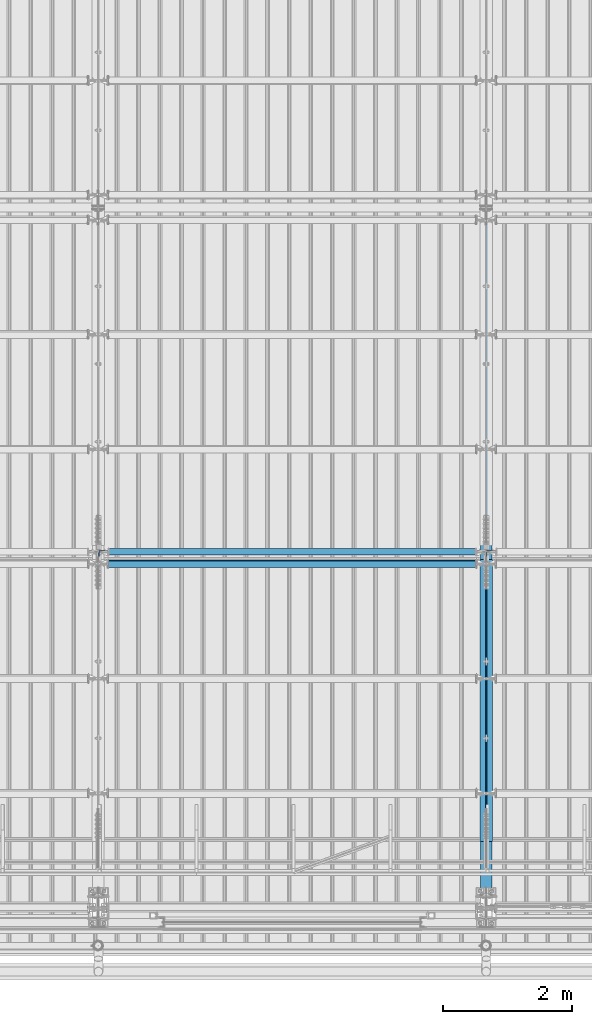
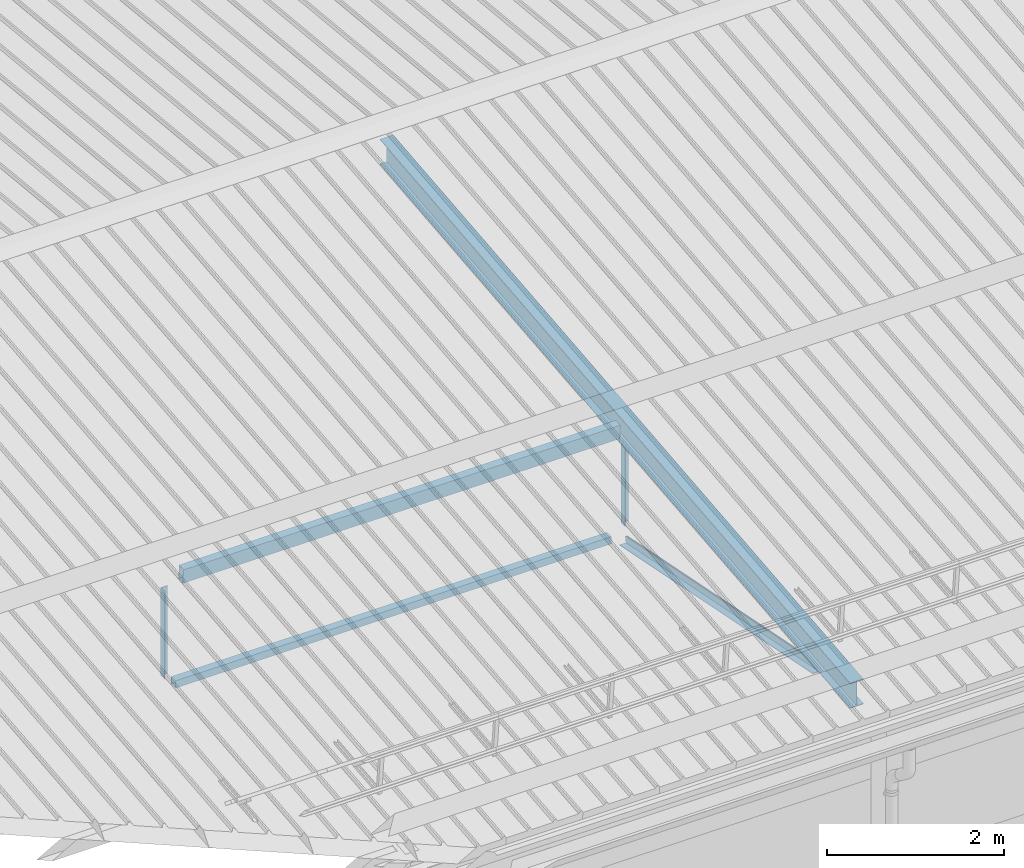
# One storey, part 252 of 709: 7 beams, 7 elements without a shape of their own.
"""IFC4 building model written with IfcOpenShell, lengths in millimetres."""

from ifc_helpers import new_model, si_unit, direction, frame, origin_with_axes, place, context, subcontext, project, spatial, polygons, material, element, aggregate, save


model = new_model("IFC4")

# Units and contexts
model_context = context("Model", 3, precision=0.2, world=origin_with_axes(), true_north=direction((0.0, 1.0)))
body_context = subcontext(model_context, "Body", "Model", "MODEL_VIEW")
ifc_project = project(units=[si_unit("LENGTHUNIT", "METRE", prefix="MILLI"), si_unit("AREAUNIT", "SQUARE_METRE"), si_unit("VOLUMEUNIT", "CUBIC_METRE"), si_unit("MASSUNIT", "GRAM", prefix="KILO"), si_unit("TIMEUNIT", "SECOND"), si_unit("PLANEANGLEUNIT", "RADIAN"), si_unit("SOLIDANGLEUNIT", "STERADIAN"), si_unit("THERMODYNAMICTEMPERATUREUNIT", "DEGREE_CELSIUS"), si_unit("LUMINOUSINTENSITYUNIT", "LUMEN")], contexts=[model_context])

# Site, building, storey
site_placement = place(None, origin_with_axes())
site = spatial("IfcSite", under=ifc_project, at=site_placement, CompositionType="ELEMENT")
building_placement = place(site_placement, origin_with_axes())
building = spatial("IfcBuilding", under=site, at=building_placement, Name="Undefined", CompositionType="ELEMENT")
storey_placement = place(building_placement, origin_with_axes())
storey = spatial("IfcBuildingStorey", under=building, at=storey_placement, Name="Undefined", CompositionType="ELEMENT", Elevation=0.0)

# Assembly, beam
assembly_1_placement = place(storey_placement, frame((16051.0, 5648.7, 7622.40002), z_axis=(0.0, -1.0, 0.0), x_axis=(0.0, 0.0, -1.0)))
assembly_1 = element("IfcElementAssembly", 1, at=assembly_1_placement, inside=storey)
ifc_material_1 = material(Name="C345-5", Category="STEEL")
beam_1_placement = place(assembly_1_placement, origin_with_axes())
beam_1 = element("IfcBeam", 2, at=beam_1_placement, material=ifc_material_1, ObjectType="436", context=body_context, shape_type="Tessellation", body=[
    polygons([(199.0491, -45.0, -45.0), (199.0491, 45.0, -45.0), (1412.4, 45.0, -45.0), (1412.4, -45.0, -45.0), (199.0491, 45.0, -39.0), (1412.4, 45.0, -39.0), (199.0491, -39.0, -39.0), (1412.4, -39.0, -39.0), (199.0491, -39.0, 45.0), (1412.4, -39.0, 45.0), (199.0491, -45.0, 45.0), (1412.4, -45.0, 45.0)], [[[1, 2, 3, 4]], [[2, 5, 6, 3]], [[5, 7, 8, 6]], [[7, 9, 10, 8]], [[9, 11, 12, 10]], [[11, 1, 4, 12]], [[6, 8, 10, 12, 4, 3]], [[11, 9, 7, 5, 2, 1]]], closed=True),
])
aggregate(assembly_1, [beam_1])

assembly_2_placement = place(storey_placement, frame((22000.0, 346.0, 7089.70002), z_axis=(1.0, 0.0, 0.0), x_axis=(0.0, 0.9950371902, 0.099503719)))
assembly_2 = element("IfcElementAssembly", 3, at=assembly_2_placement, inside=storey)
ifc_material_2 = material(Name="C355-5", Category="STEEL")
beam_2_placement = place(assembly_2_placement, origin_with_axes())
beam_2 = element("IfcBeam", 4, at=beam_2_placement, material=ifc_material_2, ObjectType="432", context=body_context, shape_type="Tessellation", body=[
    polygons([(3.80474, -173.0, -87.0), (4.70474, -164.0, -87.0), (10665.6128, -164.0, -87.0), (10664.7128, -173.0, -87.0), (4.70474, -164.0, -3.0), (10665.6128, -164.0, -3.0), (37.50474, 164.0, -3.0), (10698.4128, 164.0, -3.0), (37.50474, 164.0, -87.0), (10698.4128, 164.0, -87.0), (38.40474, 173.0, -87.0), (10699.3128, 173.0, -87.0), (38.40474, 173.0, 87.0), (10699.3128, 173.0, 87.0), (37.50474, 164.0, 87.0), (10698.4128, 164.0, 87.0), (37.50474, 164.0, 3.0), (10698.4128, 164.0, 3.0), (4.70474, -164.0, 3.0), (10665.6128, -164.0, 3.0), (4.70474, -164.0, 87.0), (10665.6128, -164.0, 87.0), (3.80474, -173.0, 87.0), (10664.7128, -173.0, 87.0)], [[[1, 2, 3, 4]], [[2, 5, 6, 3]], [[5, 7, 8, 6]], [[7, 9, 10, 8]], [[9, 11, 12, 10]], [[11, 13, 14, 12]], [[13, 15, 16, 14]], [[15, 17, 18, 16]], [[17, 19, 20, 18]], [[19, 21, 22, 20]], [[21, 23, 24, 22]], [[23, 1, 4, 24]], [[6, 8, 10, 12, 14, 16, 18, 20, 22, 24, 4, 3]], [[23, 21, 19, 17, 15, 13, 11, 9, 7, 5, 2, 1]]], closed=True),
])
aggregate(assembly_2, [beam_2])

assembly_3_placement = place(storey_placement, frame((21949.0, 350.0596, 7109.99804), z_axis=(0.0, 0.1961161349, 0.9805806757), x_axis=(0.0, 0.9805806757, -0.1961161349)))
assembly_3 = element("IfcElementAssembly", 5, at=assembly_3_placement, inside=storey)
beam_3_placement = place(assembly_3_placement, origin_with_axes())
beam_3 = element("IfcBeam", 6, at=beam_3_placement, material=ifc_material_1, ObjectType="444", context=body_context, shape_type="Tessellation", body=[
    polygons([(868.11437, -45.0, -45.0), (868.11437, 45.0, -45.0), (5317.375, 45.0, -45.0), (5317.375, -45.0, -45.0), (868.11437, 45.0, -39.0), (5317.375, 45.0, -39.0), (868.11437, -39.0, -39.0), (5317.375, -39.0, -39.0), (868.11437, -39.0, 45.0), (5317.375, -39.0, 45.0), (868.11437, -45.0, 45.0), (5317.375, -45.0, 45.0)], [[[1, 2, 3, 4]], [[2, 5, 6, 3]], [[5, 7, 8, 6]], [[7, 9, 10, 8]], [[9, 11, 12, 10]], [[11, 1, 4, 12]], [[6, 8, 10, 12, 4, 3]], [[11, 9, 7, 5, 2, 1]]], closed=True),
])
aggregate(assembly_3, [beam_3])

assembly_4_placement = place(storey_placement, frame((22051.0, 5677.0596, 6044.59804), z_axis=(0.0, 0.1961161349, 0.9805806757), x_axis=(0.0, -0.9805806757, 0.1961161349)))
assembly_4 = element("IfcElementAssembly", 7, at=assembly_4_placement, inside=storey)
beam_4_placement = place(assembly_4_placement, origin_with_axes())
beam_4 = element("IfcBeam", 8, at=beam_4_placement, material=ifc_material_1, ObjectType="444", context=body_context, shape_type="Tessellation", body=[
    polygons([(115.12039, -45.0, -45.0), (115.12039, 45.0, -45.0), (4564.38102, 45.0, -45.0), (4564.38102, -45.0, -45.0), (115.12039, 45.0, -39.0), (4564.38102, 45.0, -39.0), (115.12039, -39.0, -39.0), (4564.38102, -39.0, -39.0), (115.12039, -39.0, 45.0), (4564.38102, -39.0, 45.0), (115.12039, -45.0, 45.0), (4564.38102, -45.0, 45.0)], [[[1, 2, 3, 4]], [[2, 5, 6, 3]], [[5, 7, 8, 6]], [[7, 9, 10, 8]], [[9, 11, 12, 10]], [[11, 1, 4, 12]], [[6, 8, 10, 12, 4, 3]], [[11, 9, 7, 5, 2, 1]]], closed=True),
])
aggregate(assembly_4, [beam_4])

assembly_5_placement = place(storey_placement, frame((22051.0, 5648.7, 7622.40002), z_axis=(0.0, -1.0, 0.0), x_axis=(0.0, 0.0, -1.0)))
assembly_5 = element("IfcElementAssembly", 9, at=assembly_5_placement, inside=storey)
beam_5_placement = place(assembly_5_placement, origin_with_axes())
beam_5 = element("IfcBeam", 10, at=beam_5_placement, material=ifc_material_1, ObjectType="436", context=body_context, shape_type="Tessellation", body=[
    polygons([(199.0491, -45.0, -45.0), (199.0491, 45.0, -45.0), (1412.4, 45.0, -45.0), (1412.4, -45.0, -45.0), (199.0491, 45.0, -39.0), (1412.4, 45.0, -39.0), (199.0491, -39.0, -39.0), (1412.4, -39.0, -39.0), (199.0491, -39.0, 45.0), (1412.4, -39.0, 45.0), (199.0491, -45.0, 45.0), (1412.4, -45.0, 45.0)], [[[1, 2, 3, 4]], [[2, 5, 6, 3]], [[5, 7, 8, 6]], [[7, 9, 10, 8]], [[9, 11, 12, 10]], [[11, 1, 4, 12]], [[6, 8, 10, 12, 4, 3]], [[11, 9, 7, 5, 2, 1]]], closed=True),
])
aggregate(assembly_5, [beam_5])

assembly_6_placement = place(storey_placement, frame((16000.0, 5673.0, 6074.30002), z_axis=(0.0, -1.0, 0.0), x_axis=(1.0, 0.0, 0.0)))
assembly_6 = element("IfcElementAssembly", 11, at=assembly_6_placement, inside=storey)
ifc_material_3 = material(Name="C355", Category="STEEL")
beam_6_placement = place(assembly_6_placement, origin_with_axes())
beam_6 = element("IfcBeam", 12, at=beam_6_placement, material=ifc_material_3, ObjectType="557", context=body_context, shape_type="Tessellation", body=[
    polygons([(162.0, -47.0, -47.0), (162.0, -47.0, 47.0), (5838.0, -47.0, 47.0), (5838.0, -47.0, -47.0), (162.0, 47.0, 47.0), (5838.0, 47.0, 47.0), (162.0, 47.0, -47.0), (5838.0, 47.0, -47.0), (162.0, -50.0, -50.0), (162.0, 50.0, -50.0), (5838.0, 50.0, -50.0), (5838.0, -50.0, -50.0), (162.0, 50.0, 50.0), (5838.0, 50.0, 50.0), (162.0, -50.0, 50.0), (5838.0, -50.0, 50.0)], [[[1, 2, 3, 4]], [[2, 5, 6, 3]], [[5, 7, 8, 6]], [[7, 1, 4, 8]], [[9, 10, 11, 12]], [[10, 13, 14, 11]], [[13, 15, 16, 14]], [[15, 9, 12, 16]], [[14, 16, 12, 11], [6, 8, 4, 3]], [[15, 13, 10, 9], [7, 5, 2, 1]]], closed=True),
])
aggregate(assembly_6, [beam_6])

assembly_7_placement = place(storey_placement, frame((16000.0, 5490.04963, 7677.46908), z_axis=(0.0, 0.9950371902, 0.099503719), x_axis=(1.0, 0.0, 0.0)))
assembly_7 = element("IfcElementAssembly", 13, at=assembly_7_placement, inside=storey)
beam_7_placement = place(assembly_7_placement, origin_with_axes())
beam_7 = element("IfcBeam", 14, at=beam_7_placement, material=ifc_material_3, ObjectType="579", context=body_context, shape_type="Tessellation", body=[
    polygons([(155.0, -96.0, -46.0), (155.0, -96.0, 46.0), (5845.0, -96.0, 46.0), (5845.0, -96.0, -46.0), (155.0, 96.0, 46.0), (5845.0, 96.0, 46.0), (155.0, 96.0, -46.0), (5845.0, 96.0, -46.0), (155.0, -100.0, -50.0), (155.0, 100.0, -50.0), (5845.0, 100.0, -50.0), (5845.0, -100.0, -50.0), (155.0, 100.0, 50.0), (5845.0, 100.0, 50.0), (155.0, -100.0, 50.0), (5845.0, -100.0, 50.0)], [[[1, 2, 3, 4]], [[2, 5, 6, 3]], [[5, 7, 8, 6]], [[7, 1, 4, 8]], [[9, 10, 11, 12]], [[10, 13, 14, 11]], [[13, 15, 16, 14]], [[15, 9, 12, 16]], [[14, 16, 12, 11], [6, 8, 4, 3]], [[15, 13, 10, 9], [7, 5, 2, 1]]], closed=True),
])
aggregate(assembly_7, [beam_7])

save(model, "model.ifc")
